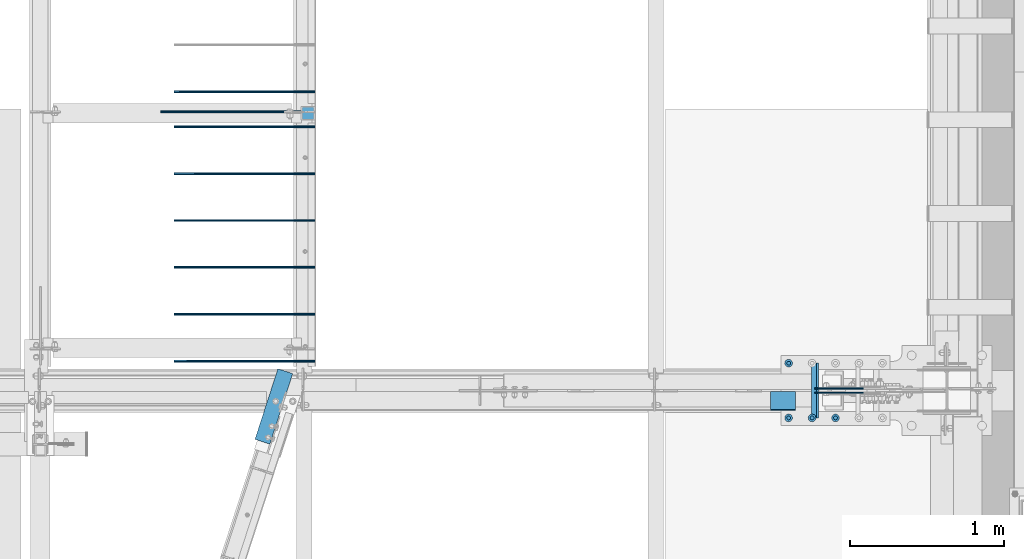
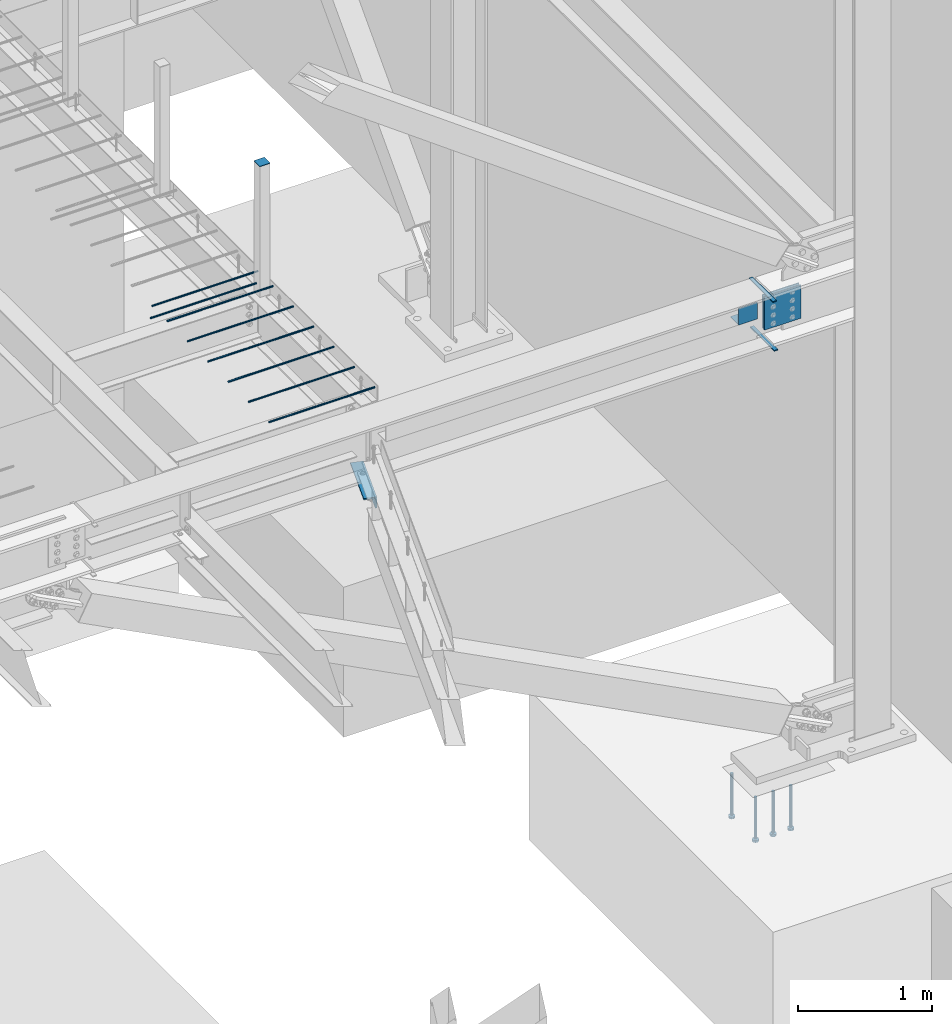
# One storey, part 818 of 1179: 19 beams, 13 elements without a shape of their own.
"""IFC2X3 building model written with IfcOpenShell, lengths in millimetres."""

from ifc_helpers import new_model, si_unit, frame, origin_with_axes, place, context, subcontext, project, spatial, faceted_brep, material, type_object, element, aggregate, save


model = new_model("IFC2X3")

# Units and contexts
model_context = context("Model", 3, precision=1e-05, world=origin_with_axes())
body_context = subcontext(model_context, "Body", "Model", "MODEL_VIEW")
ifc_project = project(units=[si_unit("LENGTHUNIT", "METRE", prefix="MILLI"), si_unit("AREAUNIT", "SQUARE_METRE"), si_unit("VOLUMEUNIT", "CUBIC_METRE"), si_unit("MASSUNIT", "GRAM", prefix="KILO"), si_unit("TIMEUNIT", "SECOND"), si_unit("PLANEANGLEUNIT", "RADIAN"), si_unit("SOLIDANGLEUNIT", "STERADIAN"), si_unit("THERMODYNAMICTEMPERATUREUNIT", "DEGREE_CELSIUS"), si_unit("LUMINOUSINTENSITYUNIT", "LUMEN")], contexts=[model_context])

# Site, building, storey
site_placement = place(None, origin_with_axes())
site = spatial("IfcSite", under=ifc_project, at=site_placement, CompositionType="ELEMENT")
building_placement = place(site_placement, origin_with_axes())
building = spatial("IfcBuilding", under=site, at=building_placement, Name="Undefined", CompositionType="ELEMENT")
storey_placement = place(building_placement, origin_with_axes())
storey = spatial("IfcBuildingStorey", under=building, at=storey_placement, Name="Undefined", CompositionType="ELEMENT", Elevation=0.0)

# Assembly, beams
assembly_1_placement = place(storey_placement, origin_with_axes())
assembly_1 = element("IfcElementAssembly", 1, at=assembly_1_placement, inside=storey, Name="BEAM", AssemblyPlace="NOTDEFINED", PredefinedType="RIGID_FRAME")
ifc_material_1 = material(Name="STEEL/A36")
beam_type_1 = type_object("IfcBeamType", Name="L4X4X1/2", PredefinedType="NOTDEFINED")
beam_1_placement = place(assembly_1_placement, frame((19858.1630152128, 5102.91300643584, 3578.22500000002), z_axis=(0.0, 0.0, -1.0), x_axis=(0.308737244064257, 0.951147367197958, 0.0)))
beam_1 = element("IfcBeam", 2, at=beam_1_placement, type_object=beam_type_1, material=ifc_material_1, Name="ANGLE", ObjectType="L4X4X1/2", context=body_context, shape_type="Brep", body=[
    faceted_brep([(1.90993887372315e-11, 50.8000000000002, -50.8000000000002), (1.90993887372315e-11, 50.8000000000002, 50.8000000000002), (481.829269964823, 50.7999999999447, 50.8000000000002), (481.829269964823, 50.7999999999447, -50.8000000000002), (1.45519152283669e-11, 38.1000000000004, 50.8000000000002), (481.829269964815, 38.0999999999331, 50.8000000000002), (0.0, 38.0999999999985, -38.0999999999999), (481.829269964815, 38.0999999999331, -38.0999999999999), (-1.81898940354586e-11, -50.7999999999997, -38.0999999999999), (481.82926996477, -50.800000000163, -38.0999999999999), (-1.81898940354586e-11, -50.7999999999997, -50.8000000000002), (481.82926996477, -50.800000000163, -50.8000000000002)], [[[0, 1, 2, 3]], [[1, 4, 5, 2]], [[4, 6, 7, 5]], [[6, 8, 9, 7]], [[8, 10, 11, 9]], [[10, 0, 3, 11]], [[5, 7, 9, 11, 3, 2]], [[10, 8, 6, 4, 1, 0]]]),
])
ifc_material_2 = material(Name="STEEL/A572-GR.50")
beam_type_2 = type_object("IfcBeamType", PredefinedType="NOTDEFINED")
beam_2_placement = place(assembly_1_placement, frame((23471.6875774438, 5435.60003662087, 3624.2625), z_axis=(0.0, -1.0, 0.0), x_axis=(-1.0, 0.0, 0.0)))
beam_2 = element("IfcBeam", 3, at=beam_2_placement, type_object=beam_type_2, material=ifc_material_2, Name="PLATE", context=body_context, shape_type="Brep", body=[
    faceted_brep([(0.0, 4.76249999999982, -179.3875), (0.0, 4.76249999999982, 179.3875), (31.7500000000036, 4.76249999999982, 179.3875), (31.7500000000036, 4.76249999999982, -179.3875), (0.0, -4.76249999999982, 179.3875), (31.7500000000036, -4.76249999999982, 179.3875), (0.0, -4.76249999999982, -179.3875), (31.7500000000036, -4.76249999999982, -179.3875)], [[[0, 1, 2, 3]], [[1, 4, 5, 2]], [[4, 6, 7, 5]], [[6, 0, 3, 7]], [[5, 7, 3, 2]], [[6, 4, 1, 0]]]),
])
beam_3_placement = place(assembly_1_placement, frame((23460.5754788212, 5435.60003662087, 4074.7155), z_axis=(0.0, -1.0, 0.0), x_axis=(-1.0, 0.0, 0.0)))
beam_3 = element("IfcBeam", 4, at=beam_3_placement, type_object=beam_type_2, material=ifc_material_2, Name="PLATE", context=body_context, shape_type="Brep", body=[
    faceted_brep([(0.0, 4.76249999999982, -179.3875), (0.0, 4.76249999999982, 179.3875), (31.7500000000036, 4.76249999999982, 179.3875), (31.7500000000036, 4.76249999999982, -179.3875), (0.0, -4.76249999999982, 179.3875), (31.7500000000036, -4.76249999999982, 179.3875), (0.0, -4.76249999999982, -179.3875), (31.7500000000036, -4.76249999999982, -179.3875)], [[[0, 1, 2, 3]], [[1, 4, 5, 2]], [[4, 6, 7, 5]], [[6, 0, 3, 7]], [[5, 7, 3, 2]], [[6, 4, 1, 0]]]),
])
beam_type_3 = type_object("IfcBeamType", PredefinedType="NOTDEFINED")
beam_4_placement = place(assembly_1_placement, frame((23242.7011803629, 5428.45623356728, 3930.65000614851), z_axis=(-1.0, 0.0, 0.0), x_axis=(0.0, -1.0, 0.0)))
beam_4 = element("IfcBeam", 5, at=beam_4_placement, type_object=beam_type_3, material=ifc_material_1, Name="BENT_PLATE", context=body_context, shape_type="Brep", body=[
    faceted_brep([(1.13323039840907e-09, -3.17500000000018, -82.5499999999993), (1.22417986858636e-09, -3.17500000000018, 82.5499999999993), (-1.13504938781261e-09, 3.17500000000018, 82.5499999999993), (-1.22599885798991e-09, 3.17500000000018, -82.5499999999993), (115.09374960925, 3.1750000427628, 82.5499999997264), (115.093749609034, 3.1750000427628, -82.5500000002758), (121.443749932894, -3.17499995487742, -82.5500000002867), (121.443749933111, -3.17499995487742, 82.5499999997119), (115.093742160368, 149.224999732594, 82.5499999996136), (115.093742160284, 149.224999732467, -82.5500000003885), (121.443742160368, 149.225000056456, 82.5499999995991), (121.443742160284, 149.225000056329, -82.5500000003995)], [[[0, 1, 2, 3]], [[3, 2, 4, 5]], [[1, 0, 6, 7]], [[5, 4, 8, 9]], [[4, 2, 1, 7, 10, 8]], [[7, 6, 11, 10]], [[6, 0, 3, 5, 9, 11]], [[10, 11, 9, 8]]]),
])
aggregate(assembly_1, [beam_2, beam_3, beam_4, beam_1])

# Assembly, beam
assembly_2_placement = place(storey_placement, origin_with_axes())
assembly_2 = element("IfcElementAssembly", 6, at=assembly_2_placement, inside=storey, Name="COLUMN", AssemblyPlace="NOTDEFINED", PredefinedType="RIGID_FRAME")
beam_type_4 = type_object("IfcBeamType", PredefinedType="NOTDEFINED")
beam_5_placement = place(assembly_2_placement, frame((20154.9, 7194.55, 5299.8685), z_axis=(1.0, 0.0, 0.0), x_axis=(0.0, 1.0, 0.0)))
beam_5 = element("IfcBeam", 7, at=beam_5_placement, type_object=beam_type_4, material=ifc_material_1, Name="PLATE", context=body_context, shape_type="Brep", body=[
    faceted_brep([(0.0, 2.38150000000041, -44.4500000000007), (0.0, 2.38150000000041, 44.4500000000007), (88.9000000000015, 2.38150000000041, 44.4500000000007), (88.9000000000015, 2.38150000000041, -44.4500000000007), (0.0, -2.38150000000041, 44.4500000000007), (88.9000000000015, -2.38150000000041, 44.4500000000007), (0.0, -2.38150000000041, -44.4500000000007), (88.9000000000015, -2.38150000000041, -44.4500000000007)], [[[0, 1, 2, 3]], [[1, 4, 5, 2]], [[4, 6, 7, 5]], [[6, 0, 3, 7]], [[5, 7, 3, 2]], [[6, 4, 1, 0]]]),
])
aggregate(assembly_2, [beam_5])

assembly_3_placement = place(storey_placement, origin_with_axes())
assembly_3 = element("IfcElementAssembly", 8, at=assembly_3_placement, inside=storey, Name="PLATE", AssemblyPlace="NOTDEFINED", PredefinedType="RIGID_FRAME")
beam_type_5 = type_object("IfcBeamType", PredefinedType="NOTDEFINED")
beam_6_placement = place(assembly_3_placement, frame((23447.8754757694, 5421.3125, 3865.5625), z_axis=(0.0, 0.0, -1.0), x_axis=(1.0, 0.0, 0.0)))
beam_6 = element("IfcBeam", 9, at=beam_6_placement, type_object=beam_type_5, material=ifc_material_2, Name="PLATE", context=body_context, shape_type="Brep", body=[
    faceted_brep([(0.0, 4.76250000000073, -152.4), (0.0, 4.76250000000073, 152.4), (317.5, 4.76250000000073, 152.4), (317.5, 4.76250000000073, -152.4), (0.0, -4.76250000000073, 152.4), (317.5, -4.76250000000073, 152.4), (0.0, -4.76250000000073, -152.4), (317.5, -4.76250000000073, -152.4)], [[[0, 1, 2, 3]], [[1, 4, 5, 2]], [[4, 6, 7, 5]], [[6, 0, 3, 7]], [[5, 7, 3, 2]], [[6, 4, 1, 0]]]),
])
aggregate(assembly_3, [beam_6])

assembly_4_placement = place(storey_placement, origin_with_axes())
assembly_4 = element("IfcElementAssembly", 10, at=assembly_4_placement, inside=storey, Name="PLATE", AssemblyPlace="NOTDEFINED", PredefinedType="RIGID_FRAME")
beam_7_placement = place(assembly_4_placement, frame((23765.3754757694, 5449.88721361182, 3865.5625), z_axis=(0.0, 0.0, -1.0), x_axis=(-1.0, 0.0, 0.0)))
beam_7 = element("IfcBeam", 11, at=beam_7_placement, type_object=beam_type_5, material=ifc_material_2, Name="PLATE", context=body_context, shape_type="Brep", body=[
    faceted_brep([(0.0, 4.76250000000073, -152.4), (0.0, 4.76250000000073, 152.4), (317.5, 4.76250000000073, 152.4), (317.5, 4.76250000000073, -152.4), (0.0, -4.76250000000073, 152.4), (317.5, -4.76250000000073, 152.4), (0.0, -4.76250000000073, -152.4), (317.5, -4.76250000000073, -152.4)], [[[0, 1, 2, 3]], [[1, 4, 5, 2]], [[4, 6, 7, 5]], [[6, 0, 3, 7]], [[5, 7, 3, 2]], [[6, 4, 1, 0]]]),
])
aggregate(assembly_4, [beam_7])

assembly_5_placement = place(storey_placement, origin_with_axes())
assembly_5 = element("IfcElementAssembly", 12, at=assembly_5_placement, inside=storey, Name="#4 DOWEL", AssemblyPlace="NOTDEFINED", PredefinedType="NOTDEFINED")
ifc_material_3 = material(Name="REBAR/A615-40")
beam_type_6 = type_object("IfcBeamType", Name="#4 DOWEL", PredefinedType="NOTDEFINED")
beam_8_placement = place(assembly_5_placement, frame((19196.05, 7246.9375, 4203.70000610352), z_axis=(0.0, 0.0, 1.0), x_axis=(1.0, 0.0, 0.0)))
beam_8 = element("IfcBeam", 13, at=beam_8_placement, type_object=beam_type_6, material=ifc_material_3, Name="#4 DOWEL", ObjectType="#4 DOWEL", context=body_context, shape_type="Brep", body=[
    faceted_brep([(0.0, -6.34999999999854, 0.0), (0.0, -4.49012806053361, -4.49012806053452), (914.399999999994, -4.49012806053452, -4.49012806042992), (914.399999999994, -6.34999999999991, 1.0550138540566e-10), (0.0, 0.0, -6.34999999999991), (914.399999999994, 0.0, -6.34999999989668), (0.0, 4.49012806053361, -4.49012806053452), (914.399999999994, 4.49012806053452, -4.49012806042992), (0.0, 6.34999999999854, 0.0), (914.399999999994, 6.34999999999991, 1.0550138540566e-10), (0.0, 4.49012806053361, 4.49012806053452), (914.399999999995, 4.49012806053452, 4.49012806064184), (0.0, 0.0, 6.34999999999991), (914.399999999995, 0.0, 6.35000000010768), (0.0, -4.49012806053361, 4.49012806053452), (914.399999999995, -4.49012806053452, 4.49012806064184)], [[[0, 1, 2, 3]], [[1, 4, 5, 2]], [[4, 6, 7, 5]], [[6, 8, 9, 7]], [[8, 10, 11, 9]], [[10, 12, 13, 11]], [[12, 14, 15, 13]], [[14, 0, 3, 15]], [[5, 7, 9, 11, 13, 15, 3, 2]], [[14, 12, 10, 8, 6, 4, 1, 0]]]),
])
aggregate(assembly_5, [beam_8])

assembly_6_placement = place(storey_placement, origin_with_axes())
assembly_6 = element("IfcElementAssembly", 14, at=assembly_6_placement, inside=storey, Name="#4 DOWEL", AssemblyPlace="NOTDEFINED", PredefinedType="NOTDEFINED")
beam_9_placement = place(assembly_6_placement, frame((19284.95, 7378.7, 4203.70000610352), z_axis=(0.0, 0.0, 1.0), x_axis=(1.0, 0.0, 0.0)))
beam_9 = element("IfcBeam", 15, at=beam_9_placement, type_object=beam_type_6, material=ifc_material_3, Name="#4 DOWEL", ObjectType="#4 DOWEL", context=body_context, shape_type="Brep", body=[
    faceted_brep([(0.0, -6.34999999999854, 0.0), (0.0, -4.49012806053361, -4.49012806053452), (914.399999999994, -4.49012806053452, -4.49012806042992), (914.399999999994, -6.34999999999991, 1.0550138540566e-10), (0.0, 0.0, -6.34999999999991), (914.399999999994, 0.0, -6.34999999989668), (0.0, 4.49012806053361, -4.49012806053452), (914.399999999994, 4.49012806053452, -4.49012806042992), (0.0, 6.34999999999854, 0.0), (914.399999999994, 6.34999999999991, 1.0550138540566e-10), (0.0, 4.49012806053361, 4.49012806053452), (914.399999999995, 4.49012806053452, 4.49012806064184), (0.0, 0.0, 6.34999999999991), (914.399999999995, 0.0, 6.35000000010768), (0.0, -4.49012806053361, 4.49012806053452), (914.399999999995, -4.49012806053452, 4.49012806064184)], [[[0, 1, 2, 3]], [[1, 4, 5, 2]], [[4, 6, 7, 5]], [[6, 8, 9, 7]], [[8, 10, 11, 9]], [[10, 12, 13, 11]], [[12, 14, 15, 13]], [[14, 0, 3, 15]], [[5, 7, 9, 11, 13, 15, 3, 2]], [[14, 12, 10, 8, 6, 4, 1, 0]]]),
])
aggregate(assembly_6, [beam_9])

assembly_7_placement = place(storey_placement, origin_with_axes())
assembly_7 = element("IfcElementAssembly", 16, at=assembly_7_placement, inside=storey, Name="#4 DOWEL", AssemblyPlace="NOTDEFINED", PredefinedType="NOTDEFINED")
beam_10_placement = place(assembly_7_placement, frame((19284.95, 7150.8935, 4203.70000610352), z_axis=(0.0, 0.0, 1.0), x_axis=(1.0, 0.0, 0.0)))
beam_10 = element("IfcBeam", 17, at=beam_10_placement, type_object=beam_type_6, material=ifc_material_3, Name="#4 DOWEL", ObjectType="#4 DOWEL", context=body_context, shape_type="Brep", body=[
    faceted_brep([(0.0, -6.34999999999854, 0.0), (0.0, -4.49012806053361, -4.49012806053452), (914.399999999994, -4.49012806053452, -4.49012806042992), (914.399999999994, -6.34999999999991, 1.0550138540566e-10), (0.0, 0.0, -6.34999999999991), (914.399999999994, 0.0, -6.34999999989668), (0.0, 4.49012806053361, -4.49012806053452), (914.399999999994, 4.49012806053452, -4.49012806042992), (0.0, 6.34999999999854, 0.0), (914.399999999994, 6.34999999999991, 1.0550138540566e-10), (0.0, 4.49012806053361, 4.49012806053452), (914.399999999995, 4.49012806053452, 4.49012806064184), (0.0, 0.0, 6.34999999999991), (914.399999999995, 0.0, 6.35000000010768), (0.0, -4.49012806053361, 4.49012806053452), (914.399999999995, -4.49012806053452, 4.49012806064184)], [[[0, 1, 2, 3]], [[1, 4, 5, 2]], [[4, 6, 7, 5]], [[6, 8, 9, 7]], [[8, 10, 11, 9]], [[10, 12, 13, 11]], [[12, 14, 15, 13]], [[14, 0, 3, 15]], [[5, 7, 9, 11, 13, 15, 3, 2]], [[14, 12, 10, 8, 6, 4, 1, 0]]]),
])
aggregate(assembly_7, [beam_10])

assembly_8_placement = place(storey_placement, origin_with_axes())
assembly_8 = element("IfcElementAssembly", 18, at=assembly_8_placement, inside=storey, Name="#4 DOWEL", AssemblyPlace="NOTDEFINED", PredefinedType="NOTDEFINED")
beam_11_placement = place(assembly_8_placement, frame((19284.95, 6846.0935, 4203.70000610352), z_axis=(0.0, 0.0, 1.0), x_axis=(1.0, 0.0, 0.0)))
beam_11 = element("IfcBeam", 19, at=beam_11_placement, type_object=beam_type_6, material=ifc_material_3, Name="#4 DOWEL", ObjectType="#4 DOWEL", context=body_context, shape_type="Brep", body=[
    faceted_brep([(0.0, -6.34999999999854, 0.0), (0.0, -4.49012806053361, -4.49012806053452), (914.399999999994, -4.49012806053452, -4.49012806042992), (914.399999999994, -6.34999999999991, 1.0550138540566e-10), (0.0, 0.0, -6.34999999999991), (914.399999999994, 0.0, -6.34999999989668), (0.0, 4.49012806053361, -4.49012806053452), (914.399999999994, 4.49012806053452, -4.49012806042992), (0.0, 6.34999999999854, 0.0), (914.399999999994, 6.34999999999991, 1.0550138540566e-10), (0.0, 4.49012806053361, 4.49012806053452), (914.399999999995, 4.49012806053452, 4.49012806064184), (0.0, 0.0, 6.34999999999991), (914.399999999995, 0.0, 6.35000000010768), (0.0, -4.49012806053361, 4.49012806053452), (914.399999999995, -4.49012806053452, 4.49012806064184)], [[[0, 1, 2, 3]], [[1, 4, 5, 2]], [[4, 6, 7, 5]], [[6, 8, 9, 7]], [[8, 10, 11, 9]], [[10, 12, 13, 11]], [[12, 14, 15, 13]], [[14, 0, 3, 15]], [[5, 7, 9, 11, 13, 15, 3, 2]], [[14, 12, 10, 8, 6, 4, 1, 0]]]),
])
aggregate(assembly_8, [beam_11])

assembly_9_placement = place(storey_placement, origin_with_axes())
assembly_9 = element("IfcElementAssembly", 20, at=assembly_9_placement, inside=storey, Name="#4 DOWEL", AssemblyPlace="NOTDEFINED", PredefinedType="NOTDEFINED")
beam_12_placement = place(assembly_9_placement, frame((19284.95, 6541.2935, 4203.70000610352), z_axis=(0.0, 0.0, 1.0), x_axis=(1.0, 0.0, 0.0)))
beam_12 = element("IfcBeam", 21, at=beam_12_placement, type_object=beam_type_6, material=ifc_material_3, Name="#4 DOWEL", ObjectType="#4 DOWEL", context=body_context, shape_type="Brep", body=[
    faceted_brep([(0.0, -6.34999999999854, 0.0), (0.0, -4.49012806053361, -4.49012806053452), (914.399999999994, -4.49012806053452, -4.49012806042992), (914.399999999994, -6.34999999999991, 1.0550138540566e-10), (0.0, 0.0, -6.34999999999991), (914.399999999994, 0.0, -6.34999999989668), (0.0, 4.49012806053361, -4.49012806053452), (914.399999999994, 4.49012806053452, -4.49012806042992), (0.0, 6.34999999999854, 0.0), (914.399999999994, 6.34999999999991, 1.0550138540566e-10), (0.0, 4.49012806053361, 4.49012806053452), (914.399999999995, 4.49012806053452, 4.49012806064184), (0.0, 0.0, 6.34999999999991), (914.399999999995, 0.0, 6.35000000010768), (0.0, -4.49012806053361, 4.49012806053452), (914.399999999995, -4.49012806053452, 4.49012806064184)], [[[0, 1, 2, 3]], [[1, 4, 5, 2]], [[4, 6, 7, 5]], [[6, 8, 9, 7]], [[8, 10, 11, 9]], [[10, 12, 13, 11]], [[12, 14, 15, 13]], [[14, 0, 3, 15]], [[5, 7, 9, 11, 13, 15, 3, 2]], [[14, 12, 10, 8, 6, 4, 1, 0]]]),
])
aggregate(assembly_9, [beam_12])

assembly_10_placement = place(storey_placement, origin_with_axes())
assembly_10 = element("IfcElementAssembly", 22, at=assembly_10_placement, inside=storey, Name="#4 DOWEL", AssemblyPlace="NOTDEFINED", PredefinedType="NOTDEFINED")
beam_13_placement = place(assembly_10_placement, frame((19284.95, 6236.4935, 4203.70000610352), z_axis=(0.0, 0.0, 1.0), x_axis=(1.0, 0.0, 0.0)))
beam_13 = element("IfcBeam", 23, at=beam_13_placement, type_object=beam_type_6, material=ifc_material_3, Name="#4 DOWEL", ObjectType="#4 DOWEL", context=body_context, shape_type="Brep", body=[
    faceted_brep([(0.0, -6.34999999999854, 0.0), (0.0, -4.49012806053361, -4.49012806053452), (914.399999999994, -4.49012806053452, -4.49012806042992), (914.399999999994, -6.34999999999991, 1.0550138540566e-10), (0.0, 0.0, -6.34999999999991), (914.399999999994, 0.0, -6.34999999989668), (0.0, 4.49012806053361, -4.49012806053452), (914.399999999994, 4.49012806053452, -4.49012806042992), (0.0, 6.34999999999854, 0.0), (914.399999999994, 6.34999999999991, 1.0550138540566e-10), (0.0, 4.49012806053361, 4.49012806053452), (914.399999999995, 4.49012806053452, 4.49012806064184), (0.0, 0.0, 6.34999999999991), (914.399999999995, 0.0, 6.35000000010768), (0.0, -4.49012806053361, 4.49012806053452), (914.399999999995, -4.49012806053452, 4.49012806064184)], [[[0, 1, 2, 3]], [[1, 4, 5, 2]], [[4, 6, 7, 5]], [[6, 8, 9, 7]], [[8, 10, 11, 9]], [[10, 12, 13, 11]], [[12, 14, 15, 13]], [[14, 0, 3, 15]], [[5, 7, 9, 11, 13, 15, 3, 2]], [[14, 12, 10, 8, 6, 4, 1, 0]]]),
])
aggregate(assembly_10, [beam_13])

assembly_11_placement = place(storey_placement, origin_with_axes())
assembly_11 = element("IfcElementAssembly", 24, at=assembly_11_placement, inside=storey, Name="#4 DOWEL", AssemblyPlace="NOTDEFINED", PredefinedType="NOTDEFINED")
beam_14_placement = place(assembly_11_placement, frame((19284.95, 5931.6935, 4203.70000610352), z_axis=(0.0, 0.0, 1.0), x_axis=(1.0, 0.0, 0.0)))
beam_14 = element("IfcBeam", 25, at=beam_14_placement, type_object=beam_type_6, material=ifc_material_3, Name="#4 DOWEL", ObjectType="#4 DOWEL", context=body_context, shape_type="Brep", body=[
    faceted_brep([(0.0, -6.34999999999854, 0.0), (0.0, -4.49012806053361, -4.49012806053452), (914.399999999994, -4.49012806053452, -4.49012806042992), (914.399999999994, -6.34999999999991, 1.0550138540566e-10), (0.0, 0.0, -6.34999999999991), (914.399999999994, 0.0, -6.34999999989668), (0.0, 4.49012806053361, -4.49012806053452), (914.399999999994, 4.49012806053452, -4.49012806042992), (0.0, 6.34999999999854, 0.0), (914.399999999994, 6.34999999999991, 1.0550138540566e-10), (0.0, 4.49012806053361, 4.49012806053452), (914.399999999995, 4.49012806053452, 4.49012806064184), (0.0, 0.0, 6.34999999999991), (914.399999999995, 0.0, 6.35000000010768), (0.0, -4.49012806053361, 4.49012806053452), (914.399999999995, -4.49012806053452, 4.49012806064184)], [[[0, 1, 2, 3]], [[1, 4, 5, 2]], [[4, 6, 7, 5]], [[6, 8, 9, 7]], [[8, 10, 11, 9]], [[10, 12, 13, 11]], [[12, 14, 15, 13]], [[14, 0, 3, 15]], [[5, 7, 9, 11, 13, 15, 3, 2]], [[14, 12, 10, 8, 6, 4, 1, 0]]]),
])
aggregate(assembly_11, [beam_14])

assembly_12_placement = place(storey_placement, origin_with_axes())
assembly_12 = element("IfcElementAssembly", 26, at=assembly_12_placement, inside=storey, Name="#4 DOWEL", AssemblyPlace="NOTDEFINED", PredefinedType="NOTDEFINED")
beam_15_placement = place(assembly_12_placement, frame((19284.95, 5626.8935, 4203.70000610352), z_axis=(0.0, 0.0, 1.0), x_axis=(1.0, 0.0, 0.0)))
beam_15 = element("IfcBeam", 27, at=beam_15_placement, type_object=beam_type_6, material=ifc_material_3, Name="#4 DOWEL", ObjectType="#4 DOWEL", context=body_context, shape_type="Brep", body=[
    faceted_brep([(0.0, -6.34999999999854, 0.0), (0.0, -4.49012806053361, -4.49012806053452), (914.399999999994, -4.49012806053452, -4.49012806042992), (914.399999999994, -6.34999999999991, 1.0550138540566e-10), (0.0, 0.0, -6.34999999999991), (914.399999999994, 0.0, -6.34999999989668), (0.0, 4.49012806053361, -4.49012806053452), (914.399999999994, 4.49012806053452, -4.49012806042992), (0.0, 6.34999999999854, 0.0), (914.399999999994, 6.34999999999991, 1.0550138540566e-10), (0.0, 4.49012806053361, 4.49012806053452), (914.399999999995, 4.49012806053452, 4.49012806064184), (0.0, 0.0, 6.34999999999991), (914.399999999995, 0.0, 6.35000000010768), (0.0, -4.49012806053361, 4.49012806053452), (914.399999999995, -4.49012806053452, 4.49012806064184)], [[[0, 1, 2, 3]], [[1, 4, 5, 2]], [[4, 6, 7, 5]], [[6, 8, 9, 7]], [[8, 10, 11, 9]], [[10, 12, 13, 11]], [[12, 14, 15, 13]], [[14, 0, 3, 15]], [[5, 7, 9, 11, 13, 15, 3, 2]], [[14, 12, 10, 8, 6, 4, 1, 0]]]),
])
aggregate(assembly_12, [beam_15])

# Assembly, beams
assembly_13_placement = place(storey_placement, origin_with_axes())
assembly_13 = element("IfcElementAssembly", 28, at=assembly_13_placement, inside=storey, Name="EMBED_PLATE", AssemblyPlace="NOTDEFINED", PredefinedType="RIGID_FRAME")
ifc_material_4 = material(Name="STEEL/A108")
beam_type_7 = type_object("IfcBeamType", Name="STUD_1-DIA", PredefinedType="NOTDEFINED")
beam_16_placement = place(assembly_13_placement, frame((23279.1, 5257.8, -393.700000000001), z_axis=(-1.0, 0.0, 0.0), x_axis=(0.0, 0.0, -1.0)))
beam_16 = element("IfcBeam", 29, at=beam_16_placement, type_object=beam_type_7, material=ifc_material_4, Name="STUD", ObjectType="STUD_1-DIA", context=body_context, shape_type="Brep", body=[
    faceted_brep([(0.0, -12.7, 0.0), (0.0, -11.0, -6.34999990463257), (382.016, -11.0, -6.34999990463257), (382.016, -12.6999998092651, 0.0), (0.0, -6.34999990463257, -11.0), (382.016, -6.34999990463257, -11.0), (0.0, 0.0, -12.6999998092651), (382.016, 0.0, -12.6999998092651), (0.0, 6.34999990463257, -11.0), (382.016, 6.34999990463257, -11.0), (0.0, 11.0, -6.34999990463257), (382.016, 11.0, -6.34999990463257), (0.0, 12.7, 0.0), (382.016, 12.6999998092651, 0.0), (0.0, 11.0, 6.34999990463257), (382.016, 11.0, 6.34999990463257), (0.0, 6.34999990463257, 11.0), (382.016, 6.34999990463257, 11.0), (0.0, 0.0, 12.6999998092651), (382.016, 0.0, 12.6999998092651), (0.0, -6.34999990463257, 11.0), (382.016, -6.34999990463257, 11.0), (0.0, -11.0, 6.34999990463257), (382.016, -11.0, 6.34999990463257), (386.08, -22.0, -12.6999998092651), (386.08, -25.3999996185303, 0.0), (386.08, -12.6999998092651, -22.0), (386.08, 0.0, -25.3999996185303), (386.08, 12.6999998092651, -22.0), (386.08, 22.0, -12.6999998092651), (386.08, 25.3999996185303, 0.0), (386.08, 22.0, 12.6999998092651), (386.08, 12.6999998092651, 22.0), (386.08, 0.0, 25.3999996185303), (386.08, -12.6999998092651, 22.0), (386.08, -22.0, 12.6999998092651), (406.4, -22.0, -12.6999998092651), (406.4, -25.3999996185303, 0.0), (406.4, -12.6999998092651, -22.0), (406.4, 0.0, -25.3999996185303), (406.4, 12.6999998092651, -22.0), (406.4, 22.0, -12.6999998092651), (406.4, 25.3999996185303, 0.0), (406.4, 22.0, 12.6999998092651), (406.4, 12.6999998092651, 22.0), (406.4, 0.0, 25.3999996185303), (406.4, -12.6999998092651, 22.0), (406.4, -22.0, 12.6999998092651)], [[[0, 1, 2, 3]], [[1, 4, 5, 2]], [[4, 6, 7, 5]], [[6, 8, 9, 7]], [[8, 10, 11, 9]], [[10, 12, 13, 11]], [[12, 14, 15, 13]], [[14, 16, 17, 15]], [[16, 18, 19, 17]], [[18, 20, 21, 19]], [[20, 22, 23, 21]], [[22, 0, 3, 23]], [[22, 20, 18, 16, 14, 12, 10, 8, 6, 4, 1, 0]], [[3, 2, 24, 25]], [[2, 5, 26, 24]], [[5, 7, 27, 26]], [[7, 9, 28, 27]], [[9, 11, 29, 28]], [[11, 13, 30, 29]], [[13, 15, 31, 30]], [[15, 17, 32, 31]], [[17, 19, 33, 32]], [[19, 21, 34, 33]], [[21, 23, 35, 34]], [[23, 3, 25, 35]], [[25, 24, 36, 37]], [[24, 26, 38, 36]], [[26, 27, 39, 38]], [[27, 28, 40, 39]], [[28, 29, 41, 40]], [[29, 30, 42, 41]], [[30, 31, 43, 42]], [[31, 32, 44, 43]], [[32, 33, 45, 44]], [[33, 34, 46, 45]], [[34, 35, 47, 46]], [[35, 25, 37, 47]], [[38, 39, 40, 41, 42, 43, 44, 45, 46, 47, 37, 36]]]),
])
beam_17_placement = place(assembly_13_placement, frame((23431.5, 5257.8, -393.700000000001), z_axis=(-1.0, 0.0, 0.0), x_axis=(0.0, 0.0, -1.0)))
beam_17 = element("IfcBeam", 30, at=beam_17_placement, type_object=beam_type_7, material=ifc_material_4, Name="STUD", ObjectType="STUD_1-DIA", context=body_context, shape_type="Brep", body=[
    faceted_brep([(0.0, -12.7, 0.0), (0.0, -11.0, -6.34999990463257), (382.016, -11.0, -6.34999990463257), (382.016, -12.6999998092651, 0.0), (0.0, -6.34999990463257, -11.0), (382.016, -6.34999990463257, -11.0), (0.0, 0.0, -12.6999998092651), (382.016, 0.0, -12.6999998092651), (0.0, 6.34999990463257, -11.0), (382.016, 6.34999990463257, -11.0), (0.0, 11.0, -6.34999990463257), (382.016, 11.0, -6.34999990463257), (0.0, 12.7, 0.0), (382.016, 12.6999998092651, 0.0), (0.0, 11.0, 6.34999990463257), (382.016, 11.0, 6.34999990463257), (0.0, 6.34999990463257, 11.0), (382.016, 6.34999990463257, 11.0), (0.0, 0.0, 12.6999998092651), (382.016, 0.0, 12.6999998092651), (0.0, -6.34999990463257, 11.0), (382.016, -6.34999990463257, 11.0), (0.0, -11.0, 6.34999990463257), (382.016, -11.0, 6.34999990463257), (386.08, -22.0, -12.6999998092651), (386.08, -25.3999996185303, 0.0), (386.08, -12.6999998092651, -22.0), (386.08, 0.0, -25.3999996185303), (386.08, 12.6999998092651, -22.0), (386.08, 22.0, -12.6999998092651), (386.08, 25.3999996185303, 0.0), (386.08, 22.0, 12.6999998092651), (386.08, 12.6999998092651, 22.0), (386.08, 0.0, 25.3999996185303), (386.08, -12.6999998092651, 22.0), (386.08, -22.0, 12.6999998092651), (406.4, -22.0, -12.6999998092651), (406.4, -25.3999996185303, 0.0), (406.4, -12.6999998092651, -22.0), (406.4, 0.0, -25.3999996185303), (406.4, 12.6999998092651, -22.0), (406.4, 22.0, -12.6999998092651), (406.4, 25.3999996185303, 0.0), (406.4, 22.0, 12.6999998092651), (406.4, 12.6999998092651, 22.0), (406.4, 0.0, 25.3999996185303), (406.4, -12.6999998092651, 22.0), (406.4, -22.0, 12.6999998092651)], [[[0, 1, 2, 3]], [[1, 4, 5, 2]], [[4, 6, 7, 5]], [[6, 8, 9, 7]], [[8, 10, 11, 9]], [[10, 12, 13, 11]], [[12, 14, 15, 13]], [[14, 16, 17, 15]], [[16, 18, 19, 17]], [[18, 20, 21, 19]], [[20, 22, 23, 21]], [[22, 0, 3, 23]], [[22, 20, 18, 16, 14, 12, 10, 8, 6, 4, 1, 0]], [[3, 2, 24, 25]], [[2, 5, 26, 24]], [[5, 7, 27, 26]], [[7, 9, 28, 27]], [[9, 11, 29, 28]], [[11, 13, 30, 29]], [[13, 15, 31, 30]], [[15, 17, 32, 31]], [[17, 19, 33, 32]], [[19, 21, 34, 33]], [[21, 23, 35, 34]], [[23, 3, 25, 35]], [[25, 24, 36, 37]], [[24, 26, 38, 36]], [[26, 27, 39, 38]], [[27, 28, 40, 39]], [[28, 29, 41, 40]], [[29, 30, 42, 41]], [[30, 31, 43, 42]], [[31, 32, 44, 43]], [[32, 33, 45, 44]], [[33, 34, 46, 45]], [[34, 35, 47, 46]], [[35, 25, 37, 47]], [[38, 39, 40, 41, 42, 43, 44, 45, 46, 47, 37, 36]]]),
])
beam_18_placement = place(assembly_13_placement, frame((23583.9, 5257.8, -393.700000000001), z_axis=(-1.0, 0.0, 0.0), x_axis=(0.0, 0.0, -1.0)))
beam_18 = element("IfcBeam", 31, at=beam_18_placement, type_object=beam_type_7, material=ifc_material_4, Name="STUD", ObjectType="STUD_1-DIA", context=body_context, shape_type="Brep", body=[
    faceted_brep([(0.0, -12.7, 0.0), (0.0, -11.0, -6.34999990463257), (382.016, -11.0, -6.34999990463257), (382.016, -12.6999998092651, 0.0), (0.0, -6.34999990463257, -11.0), (382.016, -6.34999990463257, -11.0), (0.0, 0.0, -12.6999998092651), (382.016, 0.0, -12.6999998092651), (0.0, 6.34999990463257, -11.0), (382.016, 6.34999990463257, -11.0), (0.0, 11.0, -6.34999990463257), (382.016, 11.0, -6.34999990463257), (0.0, 12.7, 0.0), (382.016, 12.6999998092651, 0.0), (0.0, 11.0, 6.34999990463257), (382.016, 11.0, 6.34999990463257), (0.0, 6.34999990463257, 11.0), (382.016, 6.34999990463257, 11.0), (0.0, 0.0, 12.6999998092651), (382.016, 0.0, 12.6999998092651), (0.0, -6.34999990463257, 11.0), (382.016, -6.34999990463257, 11.0), (0.0, -11.0, 6.34999990463257), (382.016, -11.0, 6.34999990463257), (386.08, -22.0, -12.6999998092651), (386.08, -25.3999996185303, 0.0), (386.08, -12.6999998092651, -22.0), (386.08, 0.0, -25.3999996185303), (386.08, 12.6999998092651, -22.0), (386.08, 22.0, -12.6999998092651), (386.08, 25.3999996185303, 0.0), (386.08, 22.0, 12.6999998092651), (386.08, 12.6999998092651, 22.0), (386.08, 0.0, 25.3999996185303), (386.08, -12.6999998092651, 22.0), (386.08, -22.0, 12.6999998092651), (406.4, -22.0, -12.6999998092651), (406.4, -25.3999996185303, 0.0), (406.4, -12.6999998092651, -22.0), (406.4, 0.0, -25.3999996185303), (406.4, 12.6999998092651, -22.0), (406.4, 22.0, -12.6999998092651), (406.4, 25.3999996185303, 0.0), (406.4, 22.0, 12.6999998092651), (406.4, 12.6999998092651, 22.0), (406.4, 0.0, 25.3999996185303), (406.4, -12.6999998092651, 22.0), (406.4, -22.0, 12.6999998092651)], [[[0, 1, 2, 3]], [[1, 4, 5, 2]], [[4, 6, 7, 5]], [[6, 8, 9, 7]], [[8, 10, 11, 9]], [[10, 12, 13, 11]], [[12, 14, 15, 13]], [[14, 16, 17, 15]], [[16, 18, 19, 17]], [[18, 20, 21, 19]], [[20, 22, 23, 21]], [[22, 0, 3, 23]], [[22, 20, 18, 16, 14, 12, 10, 8, 6, 4, 1, 0]], [[3, 2, 24, 25]], [[2, 5, 26, 24]], [[5, 7, 27, 26]], [[7, 9, 28, 27]], [[9, 11, 29, 28]], [[11, 13, 30, 29]], [[13, 15, 31, 30]], [[15, 17, 32, 31]], [[17, 19, 33, 32]], [[19, 21, 34, 33]], [[21, 23, 35, 34]], [[23, 3, 25, 35]], [[25, 24, 36, 37]], [[24, 26, 38, 36]], [[26, 27, 39, 38]], [[27, 28, 40, 39]], [[28, 29, 41, 40]], [[29, 30, 42, 41]], [[30, 31, 43, 42]], [[31, 32, 44, 43]], [[32, 33, 45, 44]], [[33, 34, 46, 45]], [[34, 35, 47, 46]], [[35, 25, 37, 47]], [[38, 39, 40, 41, 42, 43, 44, 45, 46, 47, 37, 36]]]),
])
beam_19_placement = place(assembly_13_placement, frame((23279.1, 5613.4, -393.700000000001), z_axis=(-1.0, 0.0, 0.0), x_axis=(0.0, 0.0, -1.0)))
beam_19 = element("IfcBeam", 32, at=beam_19_placement, type_object=beam_type_7, material=ifc_material_4, Name="STUD", ObjectType="STUD_1-DIA", context=body_context, shape_type="Brep", body=[
    faceted_brep([(0.0, -12.7, 0.0), (0.0, -11.0, -6.34999990463257), (382.016, -11.0, -6.34999990463257), (382.016, -12.6999998092651, 0.0), (0.0, -6.34999990463257, -11.0), (382.016, -6.34999990463257, -11.0), (0.0, 0.0, -12.6999998092651), (382.016, 0.0, -12.6999998092651), (0.0, 6.34999990463257, -11.0), (382.016, 6.34999990463257, -11.0), (0.0, 11.0, -6.34999990463257), (382.016, 11.0, -6.34999990463257), (0.0, 12.7, 0.0), (382.016, 12.6999998092651, 0.0), (0.0, 11.0, 6.34999990463257), (382.016, 11.0, 6.34999990463257), (0.0, 6.34999990463257, 11.0), (382.016, 6.34999990463257, 11.0), (0.0, 0.0, 12.6999998092651), (382.016, 0.0, 12.6999998092651), (0.0, -6.34999990463257, 11.0), (382.016, -6.34999990463257, 11.0), (0.0, -11.0, 6.34999990463257), (382.016, -11.0, 6.34999990463257), (386.08, -22.0, -12.6999998092651), (386.08, -25.3999996185303, 0.0), (386.08, -12.6999998092651, -22.0), (386.08, 0.0, -25.3999996185303), (386.08, 12.6999998092651, -22.0), (386.08, 22.0, -12.6999998092651), (386.08, 25.3999996185303, 0.0), (386.08, 22.0, 12.6999998092651), (386.08, 12.6999998092651, 22.0), (386.08, 0.0, 25.3999996185303), (386.08, -12.6999998092651, 22.0), (386.08, -22.0, 12.6999998092651), (406.4, -22.0, -12.6999998092651), (406.4, -25.3999996185303, 0.0), (406.4, -12.6999998092651, -22.0), (406.4, 0.0, -25.3999996185303), (406.4, 12.6999998092651, -22.0), (406.4, 22.0, -12.6999998092651), (406.4, 25.3999996185303, 0.0), (406.4, 22.0, 12.6999998092651), (406.4, 12.6999998092651, 22.0), (406.4, 0.0, 25.3999996185303), (406.4, -12.6999998092651, 22.0), (406.4, -22.0, 12.6999998092651)], [[[0, 1, 2, 3]], [[1, 4, 5, 2]], [[4, 6, 7, 5]], [[6, 8, 9, 7]], [[8, 10, 11, 9]], [[10, 12, 13, 11]], [[12, 14, 15, 13]], [[14, 16, 17, 15]], [[16, 18, 19, 17]], [[18, 20, 21, 19]], [[20, 22, 23, 21]], [[22, 0, 3, 23]], [[22, 20, 18, 16, 14, 12, 10, 8, 6, 4, 1, 0]], [[3, 2, 24, 25]], [[2, 5, 26, 24]], [[5, 7, 27, 26]], [[7, 9, 28, 27]], [[9, 11, 29, 28]], [[11, 13, 30, 29]], [[13, 15, 31, 30]], [[15, 17, 32, 31]], [[17, 19, 33, 32]], [[19, 21, 34, 33]], [[21, 23, 35, 34]], [[23, 3, 25, 35]], [[25, 24, 36, 37]], [[24, 26, 38, 36]], [[26, 27, 39, 38]], [[27, 28, 40, 39]], [[28, 29, 41, 40]], [[29, 30, 42, 41]], [[30, 31, 43, 42]], [[31, 32, 44, 43]], [[32, 33, 45, 44]], [[33, 34, 46, 45]], [[34, 35, 47, 46]], [[35, 25, 37, 47]], [[38, 39, 40, 41, 42, 43, 44, 45, 46, 47, 37, 36]]]),
])
aggregate(assembly_13, [beam_16, beam_17, beam_18, beam_19])

save(model, "model.ifc")
